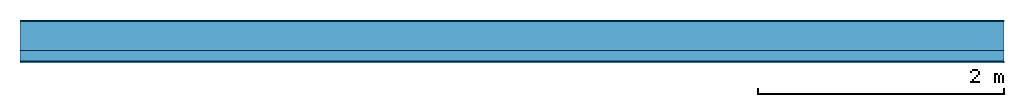
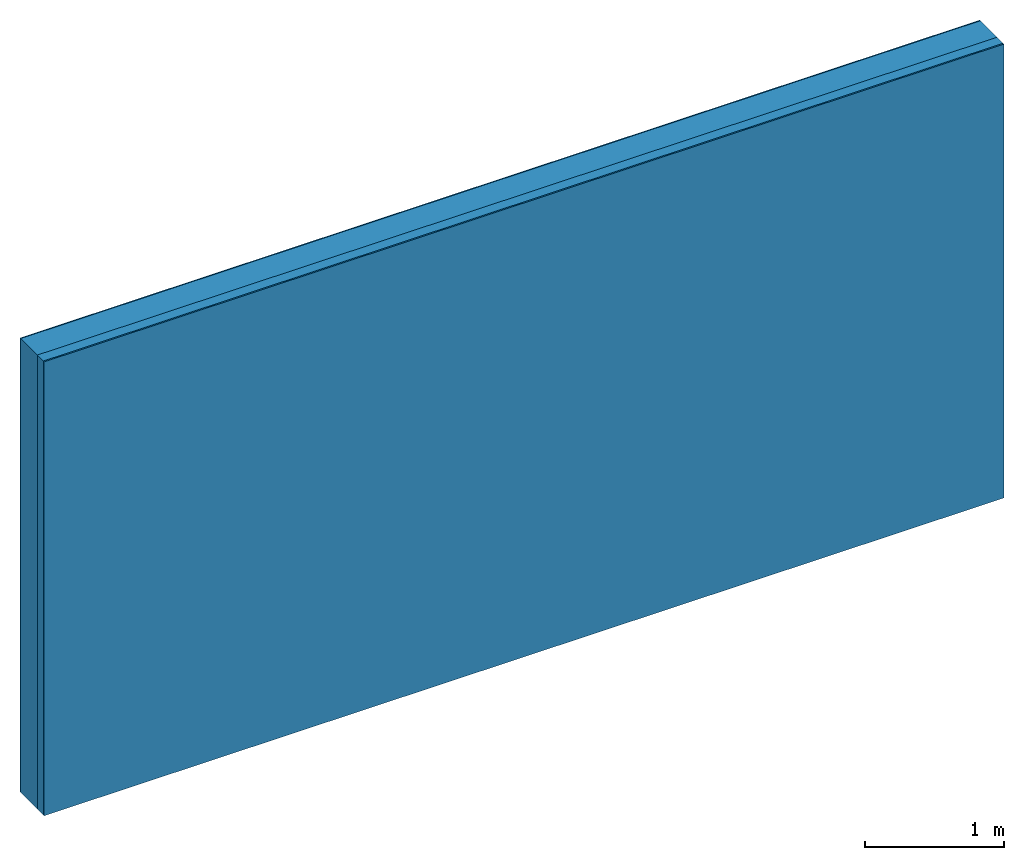
# One storey: 3 plates, 1 member, 1 element without a shape of its own.
"""IFC4 building model written with IfcOpenShell, lengths in metres."""

from ifc_helpers import new_model, si_unit, derived_unit, direction, frame, frame_2d, origin, origin_with_axes, place, context, project, spatial, rectangle, extrude, material, layer, layer_set, type_object, element, aggregate, save


model = new_model("IFC4")

# Units and contexts
plan_context = context("Plan", 3, precision=1e-05, world=origin(), true_north=direction((0.0, 1.0)))
model_context = context("Model", 3, precision=1e-05, world=origin(), true_north=direction((0.0, 1.0)))
ifc_project = project(units=[si_unit("LENGTHUNIT", "METRE"), derived_unit("SOUNDPRESSUREUNIT", [(si_unit("PRESSUREUNIT", "PASCAL", prefix="MICRO"), 0)]), si_unit("ENERGYUNIT", "JOULE", prefix="MEGA"), si_unit("MASSUNIT", "GRAM", prefix="KILO"), derived_unit("THERMALTRANSMITTANCEUNIT", [(si_unit("POWERUNIT", "WATT"), 1), (si_unit("AREAUNIT", "SQUARE_METRE"), -1), (si_unit("THERMODYNAMICTEMPERATUREUNIT", "KELVIN"), -1)]), derived_unit("AREADENSITYUNIT", [(si_unit("MASSUNIT", "GRAM", prefix="KILO"), 1), (si_unit("AREAUNIT", "SQUARE_METRE"), -1)]), derived_unit("USERDEFINED", [(si_unit("ENERGYUNIT", "JOULE", prefix="MEGA"), 1), (si_unit("AREAUNIT", "SQUARE_METRE"), -1)])], contexts=[plan_context, model_context])

# Site, building, storey
site = spatial("IfcSite", under=ifc_project)
building_placement = place(None, origin())
building = spatial("IfcBuilding", under=site, at=building_placement)
storey_placement = place(building_placement, origin())
storey = spatial("IfcBuildingStorey", under=building, at=storey_placement)

# Wall, member, plates
ifc_material_1 = material(Category="04.011")
ifc_layer_1 = layer(ifc_material_1, 0.01, Name="Surface 1")
ifc_material_2 = material(Name="Mineral wool", Category="10.008")
ifc_layer_2 = layer(ifc_material_2, 0.24, Name="outside 1st layer")
ifc_material_3 = material(Name="of the art")
ifc_layer_3 = layer(ifc_material_3, 0.0, Name="Bond")
ifc_layer_4 = layer(None, 0.087, Name="Support")
ifc_layer_5 = layer(ifc_material_3, 0.0, Name="Bond")
ifc_material_4 = material(Name="Plasterboard type A", Category="03.008")
ifc_layer_6 = layer(ifc_material_4, 0.0125, Name="1st layer")
ifc_material_5 = material(Name="joints", Category="04.017")
ifc_layer_7 = layer(ifc_material_5, 0.0, Name="Surface")
ifc_layer_set = layer_set([ifc_layer_1, ifc_layer_2, ifc_layer_3, ifc_layer_4, ifc_layer_5, ifc_layer_6, ifc_layer_7])
wall_type = type_object("IfcWallType", Name="D1022", PredefinedType="NOTDEFINED", material=ifc_layer_set)
wall_placement = place(None, frame((0.0, 0.0, 0.0), z_axis=(0.0, -1.0, 0.0), x_axis=(1.0, 0.0, 0.0)))
wall = element("IfcWall", 1, at=wall_placement, inside=storey, type_object=wall_type, material=ifc_layer_set, Name="Wall #1")
ifc_material_6 = material(Name="Solid timber panel")
member_placement = place(wall_placement, origin())
member = element("IfcMember", 2, at=member_placement, material=ifc_material_6, Name="Support", context=plan_context, shape_type="SweptSolid", body=[
    extrude(rectangle(XDim=1.0, YDim=0.087, at=frame_2d((0.5, 0.0435), x_axis=(1.0, 0.0))), frame((0.0, 4.0, 0.25), z_axis=(0.0, -1.0, 0.0), x_axis=(1.0, 0.0, 0.0)), (0.0, 0.0, 1.0), 4.0),
    extrude(rectangle(XDim=1.0, YDim=0.087, at=frame_2d((0.5, 0.0435), x_axis=(1.0, 0.0))), frame((1.0, 4.0, 0.25), z_axis=(0.0, -1.0, 0.0), x_axis=(1.0, 0.0, 0.0)), (0.0, 0.0, 1.0), 4.0),
    extrude(rectangle(XDim=1.0, YDim=0.087, at=frame_2d((0.5, 0.0435), x_axis=(1.0, 0.0))), frame((2.0, 4.0, 0.25), z_axis=(0.0, -1.0, 0.0), x_axis=(1.0, 0.0, 0.0)), (0.0, 0.0, 1.0), 4.0),
    extrude(rectangle(XDim=1.0, YDim=0.087, at=frame_2d((0.5, 0.0435), x_axis=(1.0, 0.0))), frame((3.0, 4.0, 0.25), z_axis=(0.0, -1.0, 0.0), x_axis=(1.0, 0.0, 0.0)), (0.0, 0.0, 1.0), 4.0),
    extrude(rectangle(XDim=1.0, YDim=0.087, at=frame_2d((0.5, 0.0435), x_axis=(1.0, 0.0))), frame((4.0, 4.0, 0.25), z_axis=(0.0, -1.0, 0.0), x_axis=(1.0, 0.0, 0.0)), (0.0, 0.0, 1.0), 4.0),
    extrude(rectangle(XDim=1.0, YDim=0.087, at=frame_2d((0.5, 0.0435), x_axis=(1.0, 0.0))), frame((5.0, 4.0, 0.25), z_axis=(0.0, -1.0, 0.0), x_axis=(1.0, 0.0, 0.0)), (0.0, 0.0, 1.0), 4.0),
    extrude(rectangle(XDim=1.0, YDim=0.087, at=frame_2d((0.5, 0.0435), x_axis=(1.0, 0.0))), frame((6.0, 4.0, 0.25), z_axis=(0.0, -1.0, 0.0), x_axis=(1.0, 0.0, 0.0)), (0.0, 0.0, 1.0), 4.0),
    extrude(rectangle(XDim=1.0, YDim=0.087, at=frame_2d((0.5, 0.0435), x_axis=(1.0, 0.0))), frame((7.0, 4.0, 0.25), z_axis=(0.0, -1.0, 0.0), x_axis=(1.0, 0.0, 0.0)), (0.0, 0.0, 1.0), 4.0),
])
plate_1_placement = place(wall_placement, origin())
plate_1 = element("IfcPlate", 3, at=plate_1_placement, material=ifc_material_1, Name="Surface 1", context=plan_context, shape_type="SweptSolid", body=[
    extrude(rectangle(XDim=8.0, YDim=4.0, at=frame_2d((4.0, 2.0), x_axis=(1.0, 0.0))), origin_with_axes(), (0.0, 0.0, 1.0), 0.01),
])
plate_2_placement = place(wall_placement, origin())
plate_2 = element("IfcPlate", 4, at=plate_2_placement, material=ifc_material_2, Name="outside 1st layer", context=plan_context, shape_type="SweptSolid", body=[
    extrude(rectangle(XDim=8.0, YDim=4.0, at=frame_2d((4.0, 2.0), x_axis=(1.0, 0.0))), frame((0.0, 0.0, 0.01), z_axis=(0.0, 0.0, 1.0), x_axis=(1.0, 0.0, 0.0)), (0.0, 0.0, 1.0), 0.24),
])
plate_3_placement = place(wall_placement, origin())
plate_3 = element("IfcPlate", 5, at=plate_3_placement, material=ifc_material_4, Name="1st layer", context=plan_context, shape_type="SweptSolid", body=[
    extrude(rectangle(XDim=8.0, YDim=4.0, at=frame_2d((4.0, 2.0), x_axis=(1.0, 0.0))), frame((0.0, 0.0, 0.337), z_axis=(0.0, 0.0, 1.0), x_axis=(1.0, 0.0, 0.0)), (0.0, 0.0, 1.0), 0.0125),
])
aggregate(wall, [plate_1, plate_2, member, plate_3])

save(model, "model.ifc")
